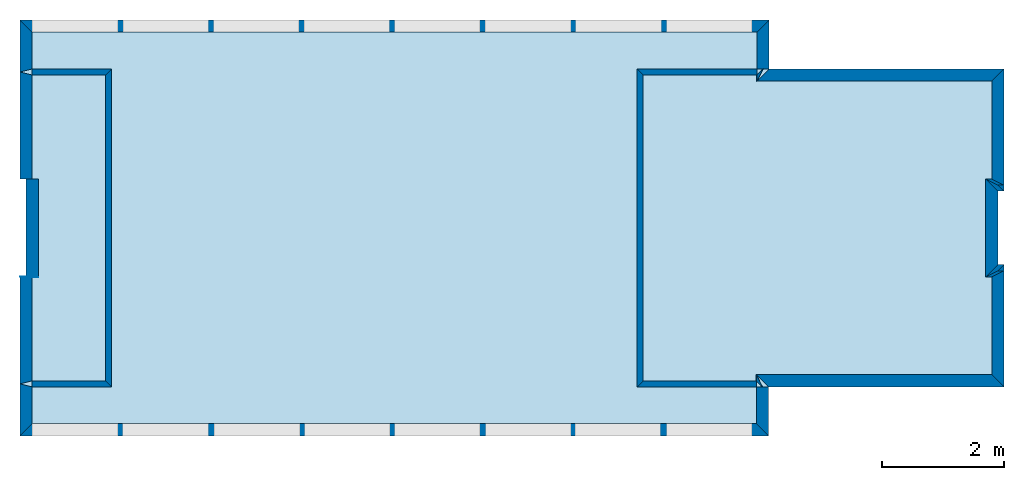
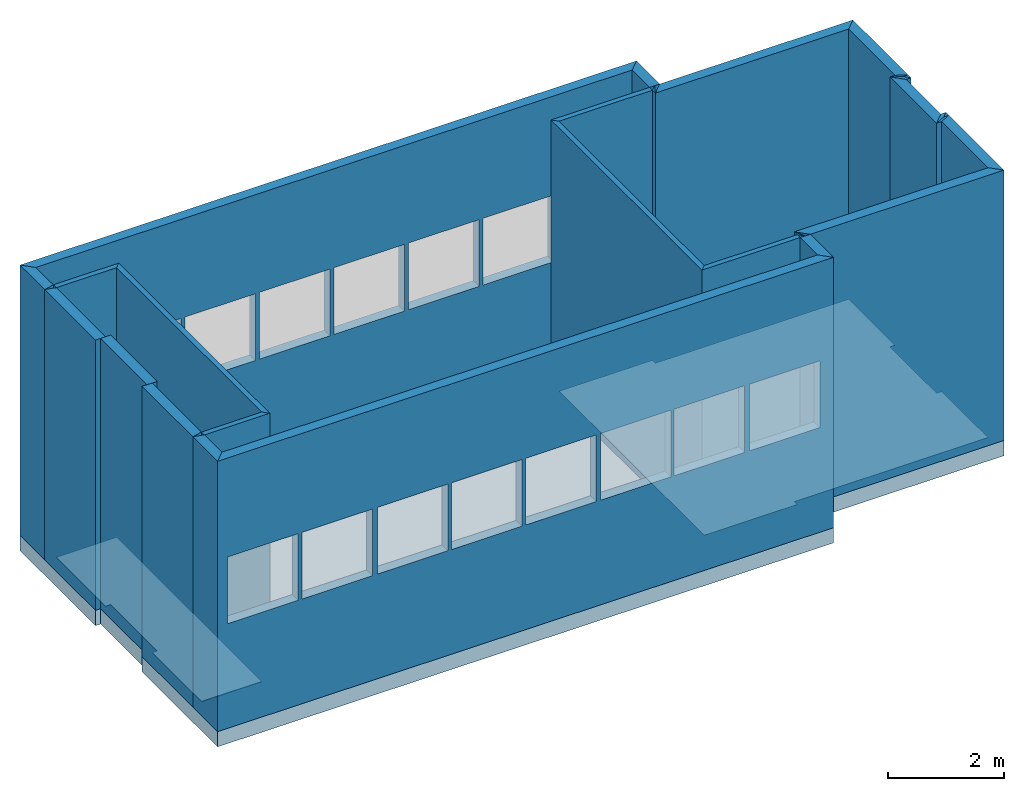
# One storey, part 1 of 17: 27 walls, 4 slabs, 16 openings.
"""IFC2X3 building model written with IfcOpenShell, lengths in metres."""

from ifc_helpers import new_model, entity, si_unit, converted_unit, derived_unit, frame, origin_with_axes, place, context, project, spatial, polyline, outline, extrude, material, layer, layer_set, layer_usage, element, save


model = new_model("IFC2X3")

# Units and contexts
context_of_model_1 = context(None, 3, world=origin_with_axes())
context_of_model_2 = context(None, 3, world=origin_with_axes())
context_of_model_3 = context(None, 2, world=origin_with_axes())
context_of_model_4 = context(None, 3, world=origin_with_axes())
ifc_project = project(units=[si_unit("LENGTHUNIT", "METRE"), si_unit("AREAUNIT", "SQUARE_METRE"), si_unit("ELECTRICCURRENTUNIT", "AMPERE"), si_unit("ELECTRICVOLTAGEUNIT", "VOLT"), si_unit("ELECTRICRESISTANCEUNIT", "OHM"), si_unit("POWERUNIT", "WATT"), si_unit("MASSUNIT", "GRAM"), si_unit("SOLIDANGLEUNIT", "STERADIAN"), si_unit("THERMODYNAMICTEMPERATUREUNIT", "KELVIN"), si_unit("PRESSUREUNIT", "PASCAL"), si_unit("LUMINOUSFLUXUNIT", "LUMEN"), si_unit("ILLUMINANCEUNIT", "LUX"), si_unit("FREQUENCYUNIT", "HERTZ"), si_unit("VOLUMEUNIT", "CUBIC_METRE"), si_unit("TIMEUNIT", "SECOND"), derived_unit("VOLUMETRICFLOWRATEUNIT", [(si_unit("TIMEUNIT", "SECOND"), -1), (si_unit("VOLUMEUNIT", "CUBIC_METRE"), 1)]), derived_unit("THERMALTRANSMITTANCEUNIT", [(si_unit("AREAUNIT", "SQUARE_METRE"), -1), (si_unit("THERMODYNAMICTEMPERATUREUNIT", "KELVIN"), -1), (si_unit("POWERUNIT", "WATT"), 1)]), converted_unit("PLANEANGLEUNIT", "DEGREE", entity("IfcPlaneAngleMeasure", 57.29577951308232), si_unit("PLANEANGLEUNIT", "RADIAN"), dimensions=[0, 0, 0, 0, 0, 0, 0])], contexts=[context_of_model_1, context_of_model_2, context_of_model_3, context_of_model_4])

# Site, building, storey
site = spatial("IfcSite", under=ifc_project, CompositionType="ELEMENT")
building_placement = place(None, origin_with_axes())
building = spatial("IfcBuilding", under=site, at=building_placement, Name="Tower", CompositionType="ELEMENT")
storey_placement = place(building_placement, frame((0.0, 0.0, 85.0), z_axis=(0.0, 0.0, 1.0), x_axis=(1.0, 0.0, 0.0)))
storey = spatial("IfcBuildingStorey", under=building, at=storey_placement, Name="Level 3", CompositionType="ELEMENT", Elevation=85.0)

# Slabs
ifc_material_1 = material()
ifc_layer_1 = layer(ifc_material_1, 0.3199999928474426, ventilated=False)
ifc_layer_set_1 = layer_set([ifc_layer_1])
ifc_layer_usage_1 = layer_usage(ifc_layer_set_1, "AXIS2", "POSITIVE", 0.0)
slab_1_placement = place(storey_placement, frame((0.1000000014901161, 1.399999976158142, 0.0), z_axis=(0.0, 0.0, 1.0), x_axis=(1.0, 0.0, 0.0)))
element("IfcSlab", 1, at=slab_1_placement, inside=storey, material=ifc_layer_usage_1, PredefinedType="FLOOR", context=context_of_model_1, shape_type="SweptSolid", body=[
    extrude(outline(polyline([(0.0, 0.0), (2.000000119209291, 0.0), (2.000000123679635, 0.0999999120831443), (3.199999932944773, 0.09999991089263416), (3.199999928474423, -1.430511357369829e-07), (5.200000405311582, -1.430511517241935e-07), (5.20000010013112, 3.839895351231112), (6.000000290865981, 3.839895315468318), (6.000001792110543, 16.088835068047), (3.400000456966503, 16.08883518427611), (3.399999975659022, 15.98883575648072), (1.800000786282108, 15.98883392065762), (1.800000790752515, 16.08883525580167), (-0.7999992926939846, 16.08883537203072), (-0.7999998398231419, 3.849762572348113), (1.720977860892539e-07, 3.849762536585327), (0.0, 0.0)])), frame((0.0, 0.0, 0.0), z_axis=(0.0, 0.0, 1.0), x_axis=(-4.470348091700783e-08, 0.9999999999999991, 0.0)), (0.0, 0.0, -1.0), 0.3199999928474426),
])
slab_2_placement = place(storey_placement, frame((-3.939895868301392, 6.600000381469727, 0.0), z_axis=(0.0, 0.0, 1.0), x_axis=(1.0, 0.0, 0.0)))
element("IfcSlab", 2, at=slab_2_placement, inside=storey, material=ifc_layer_usage_1, PredefinedType="FLOOR", context=context_of_model_1, shape_type="SweptSolid", body=[
    extrude(outline(polyline([(0.0, 0.0), (0.5999999046326159, 0.0), (0.5999961499604943, 11.84893989562933), (-4.708346343258583e-06, 11.84893965721037), (-4.191772597306827e-06, 10.54893946647561), (-5.200004597083773, 10.54893740018077), (-5.200005113657518, 11.84893759091553), (-5.800005137499329, 11.8489373524969), (-5.800000433073572, 0.009864171345491014), (-5.200000409231761, 0.009864409764117486), (-5.20000106497745, 1.960102160771091), (-7.788755649789618e-07, 1.960104227065886), (0.0, 0.0)])), frame((0.0, 0.0, 0.0), z_axis=(0.0, 0.0, 1.0), x_axis=(3.973643616619371e-07, 0.999999999999921, 0.0)), (0.0, 0.0, 1.0), 0.009999999776482582),
])
slab_3_placement = place(storey_placement, frame((-0.1000000089406967, 1.600000023841858, 0.0), z_axis=(0.0, 0.0, 1.0), x_axis=(1.0, 0.0, 0.0)))
element("IfcSlab", 3, at=slab_3_placement, inside=storey, material=ifc_layer_usage_1, PredefinedType="FLOOR", context=context_of_model_1, shape_type="SweptSolid", body=[
    extrude(outline(polyline([(0.0, 0.0), (1.60000002384186, -1.323488980084844e-23), (1.600000028498468, 0.09999990463256826), (3.19999969471246, 0.09999991953374611), (3.199999690055844, -1.490115952851313e-07), (4.80000054836273, -1.490116341429366e-07), (4.80000025033464, 3.839895397424694), (4.900000631804367, 3.839895392768063), (4.900000718422233, 5.699999953620113), (-0.09999963920562997, 5.70000018645077), (-0.09999984457333197, 3.849762340076265), (1.792685258227271e-07, 3.849762335419651), (0.0, 0.0)])), frame((0.0, 0.0, 0.0), z_axis=(0.0, 0.0, 1.0), x_axis=(-4.65661280368845e-08, 0.999999999999999, 0.0)), (0.0, 0.0, 1.0), 0.009999999776482582),
])
slab_4_placement = place(storey_placement, frame((-15.7888355255127, 6.500000476837158, 0.0), z_axis=(0.0, 0.0, 1.0), x_axis=(1.0, 0.0, 0.0)))
element("IfcSlab", 4, at=slab_4_placement, inside=storey, material=ifc_layer_usage_1, PredefinedType="FLOOR", context=context_of_model_1, shape_type="SweptSolid", body=[
    extrude(outline(polyline([(0.0, 0.0), (1.700000762939453, 0.0), (1.700001239776611, 0.1000003814697266), (3.305324554443359, 0.09904003143310547), (3.30534553527832, -0.001138687133789063), (5.000000357627869, 0.0), (5.000000476837158, 1.199999809265137), (0.0, 1.199999809265137), (0.0, 0.0)])), frame((0.0, 0.0, 0.0), z_axis=(0.0, 0.0, 1.0), x_axis=(0.0, -1.0, 0.0)), (0.0, 0.0, 1.0), 0.01999999955296516),
])

# Walls
ifc_material_2 = material(Name="Layer-Yttervegg 20.0cm")
ifc_layer_2 = layer(ifc_material_2, 0.2000000029802322, ventilated=False)
ifc_layer_set_2 = layer_set([ifc_layer_2], Name="ML-Yttervegg 20.0cm - 0.200")
ifc_layer_usage_2 = layer_usage(ifc_layer_set_2, "AXIS2", "POSITIVE", 0.0)
wall_1_placement = place(storey_placement, frame((0.09999991208314896, 3.400000095367432, 0.0), z_axis=(0.0, 0.0, 1.0), x_axis=(-1.0, -8.742277657347586e-08, 0.0)))
element("IfcWallStandardCase", 5, at=wall_1_placement, inside=storey, material=ifc_layer_usage_2, Name="Yttervegg 20.0cm", context=context_of_model_1, shape_type="SweptSolid", body=[
    extrude(outline(polyline([(0.0, 0.0), (0.0999999120831444, 0.0), (0.2999999299645421, 0.2000000476837162), (0.1999999880790708, 0.2000000476837158), (0.0, 0.0)])), frame((0.0, 0.0, 0.0), z_axis=(0.0, 0.0, 1.0), x_axis=(0.9999999999999961, -8.742278149038443e-08, 0.0)), (0.0, 0.0, 1.0), 5.68),
])
wall_2_placement = place(storey_placement, frame((-5.245365386485901e-08, 4.599999904632568, 0.0), z_axis=(0.0, 0.0, 1.0), x_axis=(1.0, 0.0, 0.0)))
element("IfcWallStandardCase", 6, at=wall_2_placement, inside=storey, material=ifc_layer_usage_2, Name="Yttervegg 20.0cm", context=context_of_model_1, shape_type="SweptSolid", body=[
    extrude(outline(polyline([(0.0, 0.0), (0.10000005394377, 0.0), (-0.09999995648704285, 0.1999998092651367), (-0.2000000250323843, 0.1999998092651367), (0.0, 0.0)])), origin_with_axes(), (0.0, 0.0, 1.0), 5.68),
])
wall_3_placement = place(storey_placement, frame((-3.739895582199097, 6.599999904632568, 0.0), z_axis=(0.0, 0.0, 1.0), x_axis=(-4.371138828673793e-08, 1.0, 0.0)))
element("IfcWallStandardCase", 7, at=wall_3_placement, inside=storey, material=ifc_layer_usage_2, Name="Yttervegg 20.0cm", context=context_of_model_1, shape_type="SweptSolid", body=[
    extrude(outline(polyline([(0.0, 0.0), (0.8000001907348633, 0.0), (0.600000381469726, 0.2000000476837155), (4.768371582176146e-07, 0.2000002861022946), (0.0, 0.0)])), frame((0.0, 0.0, 0.0), z_axis=(0.0, 0.0, 1.0), x_axis=(0.999999999999999, -4.371138963349459e-08, 0.0)), (0.0, 0.0, 1.0), 5.68),
])

# Wall, openings
ifc_material_3 = material()
ifc_layer_3 = layer(ifc_material_3, 0.2, ventilated=False)
ifc_layer_set_3 = layer_set([ifc_layer_3])
ifc_layer_usage_3 = layer_usage(ifc_layer_set_3, "AXIS2", "POSITIVE", 0.0)
wall_4_placement = place(storey_placement, frame((-3.739895582199097, 7.400000095367432, 0.0), z_axis=(0.0, 0.0, 1.0), x_axis=(-1.0, 1.509958025280866e-07, 0.0)))
wall_4 = element("IfcWallStandardCase", 8, at=wall_4_placement, inside=storey, material=ifc_layer_usage_3, context=context_of_model_1, shape_type="SweptSolid", body=[
    extrude(outline(polyline([(0.0, 0.0), (12.24893975257877, -1.058791184067875e-22), (12.04893992774211, 0.1999997936936115), (0.2000000321121897, 0.1999998248366815), (0.0, 0.0)])), frame((0.0, 0.0, 0.0), z_axis=(0.0, 0.0, 1.0), x_axis=(0.9999999999999973, 7.313809583869059e-08, 0.0)), (0.0, 0.0, 1.0), 5.68),
])
opening_1_placement = place(wall_4_placement, frame((10.64894029458421, 0.2000004635360728, 2.2), z_axis=(0.0, 0.0, 1.0), x_axis=(1.0, 0.0, 0.0)))
element("IfcOpeningElement", 9, at=opening_1_placement, cuts=wall_4, context=context_of_model_1, shape_type="SweptSolid", body=[
    extrude(outline(polyline([(0.0, 0.0), (1.399999976158142, 0.0), (1.399999976158142, 1.39999961853027), (0.0, 1.39999961853027), (0.0, 0.0)])), frame((0.0, 0.0, 0.0), z_axis=(1.153203098282065e-07, 0.9999999999999933, 0.0), x_axis=(0.0, 0.0, 1.0)), (0.0, 1.153203098282065e-07, -0.9999999999999933), 0.2),
])
opening_2_placement = place(wall_4_placement, frame((9.167823046049076, 0.2000002398935905, 2.2), z_axis=(0.0, 0.0, 1.0), x_axis=(1.0, 0.0, 0.0)))
element("IfcOpeningElement", 10, at=opening_2_placement, cuts=wall_4, context=context_of_model_1, shape_type="SweptSolid", body=[
    extrude(outline(polyline([(0.0, 0.0), (1.399999976158142, 0.0), (1.399999976158142, 1.399999618530248), (0.0, 1.399999618530248), (0.0, 0.0)])), frame((0.0, 0.0, 0.0), z_axis=(1.153203104626217e-07, 0.9999999999999934, 0.0), x_axis=(0.0, 0.0, 1.0)), (0.0, 1.153203104626217e-07, -0.9999999999999933), 0.2),
])
opening_3_placement = place(wall_4_placement, frame((7.686705797513865, 0.2000004930882655, 2.2), z_axis=(0.0, 0.0, 1.0), x_axis=(1.0, 0.0, 0.0)))
element("IfcOpeningElement", 11, at=opening_3_placement, cuts=wall_4, context=context_of_model_1, shape_type="SweptSolid", body=[
    extrude(outline(polyline([(0.0, 0.0), (1.399999976158142, 0.0), (1.399999976158142, 1.399999618530224), (0.0, 1.399999618530224), (0.0, 0.0)])), frame((0.0, 0.0, 0.0), z_axis=(1.153203098282103e-07, 0.9999999999999933, 0.0), x_axis=(0.0, 0.0, 1.0)), (0.0, 1.153203098282103e-07, -0.9999999999999933), 0.2),
])
opening_4_placement = place(wall_4_placement, frame((6.20558759530441, 0.2000002694456393, 2.2), z_axis=(0.0, 0.0, 1.0), x_axis=(1.0, 0.0, 0.0)))
element("IfcOpeningElement", 12, at=opening_4_placement, cuts=wall_4, context=context_of_model_1, shape_type="SweptSolid", body=[
    extrude(outline(polyline([(0.0, 0.0), (1.399999976158142, 0.0), (1.399999976158142, 1.3999996185302), (0.0, 1.3999996185302), (0.0, 0.0)])), frame((0.0, 0.0, 0.0), z_axis=(1.153203098282124e-07, 0.9999999999999934, 0.0), x_axis=(0.0, 0.0, 1.0)), (0.0, 1.153203098282124e-07, -0.9999999999999933), 0.2),
])
opening_5_placement = place(wall_4_placement, frame((4.724470346769271, 0.200000045803157, 2.2), z_axis=(0.0, 0.0, 1.0), x_axis=(1.0, 0.0, 0.0)))
element("IfcOpeningElement", 13, at=opening_5_placement, cuts=wall_4, context=context_of_model_1, shape_type="SweptSolid", body=[
    extrude(outline(polyline([(0.0, 0.0), (1.399999976158142, 0.0), (1.399999976158142, 1.399999618530173), (0.0, 1.399999618530173), (0.0, 0.0)])), frame((0.0, 0.0, 0.0), z_axis=(1.153203098282146e-07, 0.9999999999999933, 0.0), x_axis=(0.0, 0.0, 1.0)), (0.0, 1.153203098282146e-07, -0.9999999999999933), 0.2),
])
opening_6_placement = place(wall_4_placement, frame((3.243353098234131, 0.1999998221606747, 2.2), z_axis=(0.0, 0.0, 1.0), x_axis=(1.0, 0.0, 0.0)))
element("IfcOpeningElement", 14, at=opening_6_placement, cuts=wall_4, context=context_of_model_1, shape_type="SweptSolid", body=[
    extrude(outline(polyline([(0.0, 0.0), (1.399999976158142, 0.0), (1.399999976158142, 1.399999618530151), (0.0, 1.399999618530151), (0.0, 0.0)])), frame((0.0, 0.0, 0.0), z_axis=(1.153203104626297e-07, 0.9999999999999933, 0.0), x_axis=(0.0, 0.0, 1.0)), (0.0, 1.153203104626297e-07, -0.9999999999999933), 0.2),
])
opening_7_placement = place(wall_4_placement, frame((1.762234896024604, 0.2000000753552058, 2.2), z_axis=(0.0, 0.0, 1.0), x_axis=(1.0, 0.0, 0.0)))
element("IfcOpeningElement", 15, at=opening_7_placement, cuts=wall_4, context=context_of_model_1, shape_type="SweptSolid", body=[
    extrude(outline(polyline([(0.0, 0.0), (1.399999976158142, 0.0), (1.399999976158142, 1.399999618530126), (0.0, 1.399999618530126), (0.0, 0.0)])), frame((0.0, 0.0, 0.0), z_axis=(1.153203098282184e-07, 0.9999999999999933, 0.0), x_axis=(0.0, 0.0, 1.0)), (0.0, 1.153203098282184e-07, -0.9999999999999933), 0.2),
])
opening_8_placement = place(wall_4_placement, frame((0.2783190902079702, 0.1999998512901531, 2.2), z_axis=(0.0, 0.0, 1.0), x_axis=(1.0, 0.0, 0.0)))
element("IfcOpeningElement", 16, at=opening_8_placement, cuts=wall_4, context=context_of_model_1, shape_type="SweptSolid", body=[
    extrude(outline(polyline([(0.0, 0.0), (1.399999976158142, 0.0), (1.399999976158142, 1.399999618530102), (0.0, 1.399999618530102), (0.0, 0.0)])), frame((0.0, 0.0, 0.0), z_axis=(1.153203098282204e-07, 0.9999999999999933, 0.0), x_axis=(0.0, 0.0, 1.0)), (0.0, 1.153203098282204e-07, -0.9999999999999933), 0.2),
])

# Walls
ifc_material_4 = material()
ifc_layer_4 = layer(ifc_material_4, 0.2, ventilated=False)
ifc_layer_set_4 = layer_set([ifc_layer_4])
ifc_layer_usage_4 = layer_usage(ifc_layer_set_4, "AXIS2", "POSITIVE", 0.0)
wall_5_placement = place(storey_placement, frame((-15.98883533477783, 7.400001049041748, 0.0), z_axis=(0.0, 0.0, 1.0), x_axis=(-4.371138828673793e-08, -1.0, 0.0)))
element("IfcWallStandardCase", 17, at=wall_5_placement, inside=storey, material=ifc_layer_usage_4, context=context_of_model_1, shape_type="SweptSolid", body=[
    extrude(outline(polyline([(0.0, 0.0), (0.8500008583068847, 0.0), (0.8000006675720213, 0.1999998092651369), (0.1999998092651368, 0.1999998092651379), (0.0, 0.0)])), frame((0.0, 0.0, 0.0), z_axis=(0.0, 0.0, 1.0), x_axis=(0.9999999999999991, 4.371139137835724e-08, 0.0)), (0.0, 0.0, 1.0), 5.68),
])
ifc_material_5 = material()
ifc_layer_5 = layer(ifc_material_5, 0.1, ventilated=False)
ifc_layer_set_5 = layer_set([ifc_layer_5])
ifc_layer_usage_5 = layer_usage(ifc_layer_set_5, "AXIS2", "POSITIVE", 0.0)
wall_6_placement = place(storey_placement, frame((-15.7888355255127, 6.500000476837158, 0.0), z_axis=(0.0, 0.0, 1.0), x_axis=(1.0, 0.0, 0.0)))
element("IfcWallStandardCase", 18, at=wall_6_placement, inside=storey, material=ifc_layer_usage_5, context=context_of_model_1, shape_type="SweptSolid", body=[
    extrude(outline(polyline([(0.0, 0.0), (1.199999809265137, 0.0), (1.300000190734863, 0.09999990463256836), (0.0, 0.09999990463256836), (0.0, 0.0)])), origin_with_axes(), (0.0, 0.0, 1.0), 5.68),
])
wall_7_placement = place(storey_placement, frame((-14.58883571624756, 6.500000476837158, 0.0), z_axis=(0.0, 0.0, 1.0), x_axis=(-4.371138828673793e-08, -1.0, 0.0)))
element("IfcWallStandardCase", 19, at=wall_7_placement, inside=storey, material=ifc_layer_usage_5, context=context_of_model_1, shape_type="SweptSolid", body=[
    extrude(outline(polyline([(0.0, 0.0), (5.000000476837157, 0.0), (5.100000500679015, 0.1000003814697265), (-0.09999990463256864, 0.1000003814697269), (0.0, 0.0)])), frame((0.0, 0.0, 0.0), z_axis=(0.0, 0.0, 1.0), x_axis=(0.9999999999999991, 4.371139015770818e-08, 0.0)), (0.0, 0.0, 1.0), 5.68),
])
wall_8_placement = place(storey_placement, frame((-14.58883571624756, 1.5, 0.0), z_axis=(0.0, 0.0, 1.0), x_axis=(-1.0, 1.509958025280866e-07, 0.0)))
element("IfcWallStandardCase", 20, at=wall_8_placement, inside=storey, material=ifc_layer_usage_5, context=context_of_model_1, shape_type="SweptSolid", body=[
    extrude(outline(polyline([(0.0, 0.0), (1.199999809265142, 0.0), (1.199999799331019, 0.100000143051147), (-0.1000003914038372, 0.1000000139077105), (0.0, 0.0)])), frame((0.0, 0.0, 0.0), z_axis=(0.0, 0.0, 1.0), x_axis=(0.9999999999999987, 5.165470854219175e-08, 0.0)), (0.0, 0.0, 1.0), 5.68),
])
ifc_material_6 = material()
ifc_layer_6 = layer(ifc_material_6, 0.2, ventilated=False)
ifc_layer_set_6 = layer_set([ifc_layer_6])
ifc_layer_usage_6 = layer_usage(ifc_layer_set_6, "AXIS2", "POSITIVE", 0.0)
wall_9_placement = place(storey_placement, frame((-15.98883533477783, 1.450000047683716, 0.0), z_axis=(0.0, 0.0, 1.0), x_axis=(-4.371138828673793e-08, -1.0, 0.0)))
element("IfcWallStandardCase", 21, at=wall_9_placement, inside=storey, material=ifc_layer_usage_6, context=context_of_model_1, shape_type="SweptSolid", body=[
    extrude(outline(polyline([(0.0, 0.0), (0.8500000834465025, 0.0), (0.6500000953674314, 0.1999998092651363), (0.05000007152557353, 0.1999998092651369), (0.0, 0.0)])), frame((0.0, 0.0, 0.0), z_axis=(0.0, 0.0, 1.0), x_axis=(0.9999999999999991, 4.371138942904995e-08, 0.0)), (0.0, 0.0, 1.0), 5.68),
])

# Wall, openings
ifc_material_7 = material()
ifc_layer_7 = layer(ifc_material_7, 0.2, ventilated=False)
ifc_layer_set_7 = layer_set([ifc_layer_7])
ifc_layer_usage_7 = layer_usage(ifc_layer_set_7, "AXIS2", "POSITIVE", 0.0)
wall_10_placement = place(storey_placement, frame((-15.98883533477783, 0.5999999642372131, 0.0), z_axis=(0.0, 0.0, 1.0), x_axis=(1.0, 0.0, 0.0)))
wall_10 = element("IfcWallStandardCase", 22, at=wall_10_placement, inside=storey, material=ifc_layer_usage_7, context=context_of_model_1, shape_type="SweptSolid", body=[
    extrude(outline(polyline([(0.0, 0.0), (12.23907279968262, 0.0), (12.03907299041748, 0.199999988079071), (0.1999998092651367, 0.199999988079071), (0.0, 0.0)])), origin_with_axes(), (0.0, 0.0, 1.0), 5.68),
])
opening_9_placement = place(wall_10_placement, frame((0.1999998092651367, 0.199999988079071, 2.2), z_axis=(0.0, 0.0, 1.0), x_axis=(1.0, 0.0, 0.0)))
element("IfcOpeningElement", 23, at=opening_9_placement, cuts=wall_10, context=context_of_model_1, shape_type="SweptSolid", body=[
    extrude(outline(polyline([(0.0, 0.0), (1.399999976158142, 0.0), (1.399999976158142, 1.399999618530103), (0.0, 1.399999618530103), (0.0, 0.0)])), frame((0.0, 0.0, 0.0), z_axis=(0.0, 1.0, 0.0), x_axis=(0.0, 0.0, 1.0)), (0.0, 0.0, -1.0), 0.2),
])
opening_10_placement = place(wall_10_placement, frame((1.679572105407715, 0.199999988079071, 2.2), z_axis=(0.0, 0.0, 1.0), x_axis=(1.0, 0.0, 0.0)))
element("IfcOpeningElement", 24, at=opening_10_placement, cuts=wall_10, context=context_of_model_1, shape_type="SweptSolid", body=[
    extrude(outline(polyline([(0.0, 0.0), (1.399999976158142, 0.0), (1.399999976158142, 1.399999618530103), (0.0, 1.399999618530103), (0.0, 0.0)])), frame((0.0, 0.0, 0.0), z_axis=(0.0, 1.0, 0.0), x_axis=(0.0, 0.0, 1.0)), (0.0, 0.0, -1.0), 0.2),
])
opening_11_placement = place(wall_10_placement, frame((3.175571441650391, 0.199999988079071, 2.2), z_axis=(0.0, 0.0, 1.0), x_axis=(1.0, 0.0, 0.0)))
element("IfcOpeningElement", 25, at=opening_11_placement, cuts=wall_10, context=context_of_model_1, shape_type="SweptSolid", body=[
    extrude(outline(polyline([(0.0, 0.0), (1.399999976158142, 0.0), (1.399999976158142, 1.399999618530103), (0.0, 1.399999618530103), (0.0, 0.0)])), frame((0.0, 0.0, 0.0), z_axis=(0.0, 1.0, 0.0), x_axis=(0.0, 0.0, 1.0)), (0.0, 0.0, -1.0), 0.2),
])
opening_12_placement = place(wall_10_placement, frame((4.649572372436523, 0.199999988079071, 2.2), z_axis=(0.0, 0.0, 1.0), x_axis=(1.0, 0.0, 0.0)))
element("IfcOpeningElement", 26, at=opening_12_placement, cuts=wall_10, context=context_of_model_1, shape_type="SweptSolid", body=[
    extrude(outline(polyline([(0.0, 0.0), (1.399999976158142, 0.0), (1.399999976158142, 1.399999618530103), (0.0, 1.399999618530103), (0.0, 0.0)])), frame((0.0, 0.0, 0.0), z_axis=(0.0, 1.0, 0.0), x_axis=(0.0, 0.0, 1.0)), (0.0, 0.0, -1.0), 0.2),
])
opening_13_placement = place(wall_10_placement, frame((6.123573303222656, 0.199999988079071, 2.2), z_axis=(0.0, 0.0, 1.0), x_axis=(1.0, 0.0, 0.0)))
element("IfcOpeningElement", 27, at=opening_13_placement, cuts=wall_10, context=context_of_model_1, shape_type="SweptSolid", body=[
    extrude(outline(polyline([(0.0, 0.0), (1.399999976158142, 0.0), (1.399999976158142, 1.399999618530103), (0.0, 1.399999618530103), (0.0, 0.0)])), frame((0.0, 0.0, 0.0), z_axis=(0.0, 1.0, 0.0), x_axis=(0.0, 0.0, 1.0)), (0.0, 0.0, -1.0), 0.2),
])
opening_14_placement = place(wall_10_placement, frame((7.608574867248535, 0.199999988079071, 2.2), z_axis=(0.0, 0.0, 1.0), x_axis=(1.0, 0.0, 0.0)))
element("IfcOpeningElement", 28, at=opening_14_placement, cuts=wall_10, context=context_of_model_1, shape_type="SweptSolid", body=[
    extrude(outline(polyline([(0.0, 0.0), (1.399999976158142, 0.0), (1.399999976158142, 1.399999618530103), (0.0, 1.399999618530103), (0.0, 0.0)])), frame((0.0, 0.0, 0.0), z_axis=(0.0, 1.0, 0.0), x_axis=(0.0, 0.0, 1.0)), (0.0, 0.0, -1.0), 0.2),
])
opening_15_placement = place(wall_10_placement, frame((9.071574211120605, 0.199999988079071, 2.2), z_axis=(0.0, 0.0, 1.0), x_axis=(1.0, 0.0, 0.0)))
element("IfcOpeningElement", 29, at=opening_15_placement, cuts=wall_10, context=context_of_model_1, shape_type="SweptSolid", body=[
    extrude(outline(polyline([(0.0, 0.0), (1.399999976158142, 0.0), (1.399999976158142, 1.399999618530103), (0.0, 1.399999618530103), (0.0, 0.0)])), frame((0.0, 0.0, 0.0), z_axis=(0.0, 1.0, 0.0), x_axis=(0.0, 0.0, 1.0)), (0.0, 0.0, -1.0), 0.2),
])
opening_16_placement = place(wall_10_placement, frame((10.56757545471191, 0.199999988079071, 2.2), z_axis=(0.0, 0.0, 1.0), x_axis=(1.0, 0.0, 0.0)))
element("IfcOpeningElement", 30, at=opening_16_placement, cuts=wall_10, context=context_of_model_1, shape_type="SweptSolid", body=[
    extrude(outline(polyline([(0.0, 0.0), (1.399999976158142, 0.0), (1.399999976158142, 1.399999618530103), (0.0, 1.399999618530103), (0.0, 0.0)])), frame((0.0, 0.0, 0.0), z_axis=(0.0, 1.0, 0.0), x_axis=(0.0, 0.0, 1.0)), (0.0, 0.0, -1.0), 0.2),
])

# Walls
wall_11_placement = place(storey_placement, frame((-3.749762535095215, 0.5999999642372131, 0.0), z_axis=(0.0, 0.0, 1.0), x_axis=(-4.371138828673793e-08, 1.0, 0.0)))
element("IfcWallStandardCase", 31, at=wall_11_placement, inside=storey, material=ifc_layer_usage_2, Name="Yttervegg 20.0cm", context=context_of_model_1, shape_type="SweptSolid", body=[
    extrude(outline(polyline([(0.0, 0.0), (0.8000000119209291, -6.617444900424221e-24), (0.800000011920929, 0.1999998092651365), (0.1999999880790711, 0.1999998092651364), (0.0, 0.0)])), frame((0.0, 0.0, 0.0), z_axis=(0.0, 0.0, 1.0), x_axis=(0.999999999999999, -4.371138996685581e-08, 0.0)), (0.0, 0.0, 1.0), 5.68),
])
wall_12_placement = place(storey_placement, frame((-3.949762344360352, 1.5, 0.0), z_axis=(0.0, 0.0, 1.0), x_axis=(-1.0, 1.509958025280866e-07, 0.0)))
element("IfcWallStandardCase", 32, at=wall_12_placement, inside=storey, material=ifc_layer_usage_5, context=context_of_model_1, shape_type="SweptSolid", body=[
    extrude(outline(polyline([(0.0, 0.0), (1.850237846374515, 0.0), (1.950237744564166, 0.1000000302847687), (-6.442918429059665e-09, 0.1000000238418577), (0.0, 0.0)])), frame((0.0, 0.0, 0.0), z_axis=(0.0, 0.0, 1.0), x_axis=(0.9999999999999962, 8.656662868464251e-08, 0.0)), (0.0, 0.0, 1.0), 5.68),
])
wall_13_placement = place(storey_placement, frame((-5.800000190734863, 1.50000011920929, 0.0), z_axis=(0.0, 0.0, 1.0), x_axis=(-4.371138828673793e-08, 1.0, 0.0)))
element("IfcWallStandardCase", 33, at=wall_13_placement, inside=storey, material=ifc_layer_usage_5, context=context_of_model_1, shape_type="SweptSolid", body=[
    extrude(outline(polyline([(0.0, 0.0), (5.000000357627869, 0.0), (5.100000262260437, 0.0999999046325687), (-0.1000000238418578, 0.09999990463256829), (0.0, 0.0)])), frame((0.0, 0.0, 0.0), z_axis=(0.0, 0.0, 1.0), x_axis=(0.9999999999999991, -4.371138995641915e-08, 0.0)), (0.0, 0.0, 1.0), 5.68),
])
wall_14_placement = place(storey_placement, frame((-5.800000190734863, 6.500000476837158, 0.0), z_axis=(0.0, 0.0, 1.0), x_axis=(1.0, 0.0, 0.0)))
element("IfcWallStandardCase", 34, at=wall_14_placement, inside=storey, material=ifc_layer_usage_5, context=context_of_model_1, shape_type="SweptSolid", body=[
    extrude(outline(polyline([(0.0, 0.0), (1.860104560852051, 0.0), (1.860104322433472, 0.09999990463256836), (-0.09999990463256836, 0.09999990463256836), (0.0, 0.0)])), origin_with_axes(), (0.0, 0.0, 1.0), 5.68),
])
wall_15_placement = place(storey_placement, frame((0.1000000014901161, 1.399999976158142, 0.0), z_axis=(0.0, 0.0, 1.0), x_axis=(-4.371138828673793e-08, 1.0, 0.0)))
element("IfcWallStandardCase", 35, at=wall_15_placement, inside=storey, material=ifc_layer_usage_2, Name="Yttervegg 20.0cm", context=context_of_model_1, shape_type="SweptSolid", body=[
    extrude(outline(polyline([(0.0, 0.0), (2.000000119209291, 0.0), (1.800000080466272, 0.2000000044703497), (0.2000000566244123, 0.2000000014901143), (0.0, 0.0)])), frame((0.0, 0.0, 0.0), z_axis=(0.0, 0.0, 1.0), x_axis=(1.0, 9.92090919679804e-10, 0.0)), (0.0, 0.0, 1.0), 5.68),
])
wall_16_placement = place(storey_placement, frame((0.09999991953372955, 3.299999952316284, 0.0), z_axis=(0.0, 0.0, 1.0), x_axis=(-1.0, -8.742277657347586e-08, 0.0)))
element("IfcWallStandardCase", 36, at=wall_16_placement, inside=storey, material=ifc_layer_usage_5, context=context_of_model_1, shape_type="SweptSolid", body=[
    extrude(outline(polyline([(0.0, 0.0), (0.09999991208314898, 0.0), (0.2999999076128005, 0.09999990463256865), (0.2000000029802322, 0.09999990463256886), (0.0, 0.0)])), frame((0.0, 0.0, 0.0), z_axis=(0.0, 0.0, 1.0), x_axis=(0.9999999999999961, -8.742278149038043e-08, 0.0)), (0.0, 0.0, 1.0), 5.68),
])
wall_17_placement = place(storey_placement, frame((4.579669976578771e-15, 3.400000095367432, 0.0), z_axis=(0.0, 0.0, 1.0), x_axis=(-4.371138828673793e-08, 1.0, 0.0)))
element("IfcWallStandardCase", 37, at=wall_17_placement, inside=storey, material=ifc_layer_usage_2, Name="Yttervegg 20.0cm", context=context_of_model_1, shape_type="SweptSolid", body=[
    extrude(outline(polyline([(0.0, 0.0), (1.199999809265139, 0.0), (1.399999627272554, 0.2000000162901147), (-0.200000038941438, 0.1999999968213553), (0.0, 0.0)])), frame((0.0, 0.0, 0.0), z_axis=(0.0, 0.0, 1.0), x_axis=(1.0, -1.01701678366724e-15, 0.0)), (0.0, 0.0, 1.0), 5.68),
])
wall_18_placement = place(storey_placement, frame((-7.450580596923828e-08, 4.699999809265137, 0.0), z_axis=(0.0, 0.0, 1.0), x_axis=(1.0, 0.0, 0.0)))
element("IfcWallStandardCase", 38, at=wall_18_placement, inside=storey, material=ifc_layer_usage_5, context=context_of_model_1, shape_type="SweptSolid", body=[
    extrude(outline(polyline([(0.0, 0.0), (0.1000000685453415, 0.0), (-0.09999993443489075, 0.09999990463256836), (-0.2000000029802322, 0.09999990463256836), (0.0, 0.0)])), origin_with_axes(), (0.0, 0.0, 1.0), 5.68),
])
wall_19_placement = place(storey_placement, frame((0.1000000014901161, 4.599999904632568, 0.0), z_axis=(0.0, 0.0, 1.0), x_axis=(-4.371138828673793e-08, 1.0, 0.0)))
element("IfcWallStandardCase", 39, at=wall_19_placement, inside=storey, material=ifc_layer_usage_2, Name="Yttervegg 20.0cm", context=context_of_model_1, shape_type="SweptSolid", body=[
    extrude(outline(polyline([(0.0, 0.0), (2.00000047683716, 0.0), (1.800000676512718, 0.2000000044703375), (0.1999998182058313, 0.2000000014901266), (0.0, 0.0)])), frame((0.0, 0.0, 0.0), z_axis=(0.0, 0.0, 1.0), x_axis=(1.0, 9.920829221486003e-10, 0.0)), (0.0, 0.0, 1.0), 5.68),
])
wall_20_placement = place(storey_placement, frame((0.09999991208314896, 6.600000381469727, 0.0), z_axis=(0.0, 0.0, 1.0), x_axis=(-1.0, -1.509958025280866e-07, 0.0)))
element("IfcWallStandardCase", 40, at=wall_20_placement, inside=storey, material=ifc_layer_usage_2, Name="Yttervegg 20.0cm", context=context_of_model_1, shape_type="SweptSolid", body=[
    extrude(outline(polyline([(0.0, 0.0), (3.839895494282275, 0.0), (4.039895566801911, 0.1999997844291838), (0.200000020365571, 0.1999997844291904), (0.0, 0.0)])), frame((0.0, 0.0, 0.0), z_axis=(0.0, 0.0, 1.0), x_axis=(0.9999999999999997, -2.681607627142525e-08, 0.0)), (0.0, 0.0, 1.0), 5.68),
])
wall_21_placement = place(storey_placement, frame((-3.839895725250244, 6.599999904632568, 0.0), z_axis=(0.0, 0.0, 1.0), x_axis=(-4.371138828673793e-08, 1.0, 0.0)))
element("IfcWallStandardCase", 41, at=wall_21_placement, inside=storey, material=ifc_layer_usage_5, context=context_of_model_1, shape_type="SweptSolid", body=[
    extrude(outline(polyline([(0.0, 0.0), (-3.371739842166629e-07, -3.371755919557258e-07), (0.1414208841930086, -1.387778780781446e-17), (0.2121316634626929, 0.07071111644688433), (0.0, 0.0)])), frame((0.0, 0.0, 0.0), z_axis=(0.0, 0.0, 1.0), x_axis=(-0.707105064396276, 0.707108497972651, 0.0)), (0.0, 0.0, 1.0), 5.68),
])
wall_22_placement = place(storey_placement, frame((-3.849762439727783, 1.399999976158142, 0.0), z_axis=(0.0, 0.0, 1.0), x_axis=(1.0, 0.0, 0.0)))
element("IfcWallStandardCase", 42, at=wall_22_placement, inside=storey, material=ifc_layer_usage_5, context=context_of_model_1, shape_type="SweptSolid", body=[
    extrude(outline(polyline([(0.0, 0.0), (0.0, 0.0), (0.2236067977500044, 0.0), (0.1341640360004059, 0.04472132756277154), (0.0, 0.0)])), frame((0.0, 0.0, 0.0), z_axis=(0.0, 0.0, 1.0), x_axis=(-0.4472131690037871, 0.8944274042478741, 0.0)), (0.0, 0.0, 1.0), 5.68),
])
wall_23_placement = place(storey_placement, frame((-3.749762535095215, 1.399999976158142, 0.0), z_axis=(0.0, 0.0, 1.0), x_axis=(1.0, 0.0, 0.0)))
element("IfcWallStandardCase", 43, at=wall_23_placement, inside=storey, material=ifc_layer_usage_2, Name="Yttervegg 20.0cm", context=context_of_model_1, shape_type="SweptSolid", body=[
    extrude(outline(polyline([(0.0, 0.0), (3.849762536585331, 0.0), (3.649762526154518, 0.2000000476837158), (-0.1999998092651367, 0.2000000476837158), (0.0, 0.0)])), origin_with_axes(), (0.0, 0.0, 1.0), 5.68),
])
wall_24_placement = place(storey_placement, frame((-15.98883533477783, 6.550000190734863, 0.0), z_axis=(0.0, 0.0, 1.0), x_axis=(-4.371138828673793e-08, -1.0, 0.0)))
element("IfcWallStandardCase", 44, at=wall_24_placement, inside=storey, material=ifc_layer_usage_2, Name="Yttervegg 20.0cm", context=context_of_model_1, shape_type="SweptSolid", body=[
    extrude(outline(polyline([(0.0, 0.0), (1.750000476837158, 0.0), (1.750000476837157, 0.1999998092651369), (0.04999971389770468, 0.1999998092651365), (0.0, 0.0)])), frame((0.0, 0.0, 0.0), z_axis=(0.0, 0.0, 1.0), x_axis=(0.9999999999999991, 4.371138957212315e-08, 0.0)), (0.0, 0.0, 1.0), 5.68),
])
wall_25_placement = place(storey_placement, frame((-15.88883590698242, 4.799999237060547, 0.0), z_axis=(0.0, 0.0, 1.0), x_axis=(1.148381556959066e-06, -1.0, 0.0)))
element("IfcWallStandardCase", 45, at=wall_25_placement, inside=storey, material=ifc_layer_usage_2, Name="Yttervegg 20.0cm", context=context_of_model_1, shape_type="SweptSolid", body=[
    extrude(outline(polyline([(0.0, 0.0), (1.599999189377968, 0.0), (1.60532355194039, 0.1990384992072016), (2.384196089756942e-07, 0.2000007629393097), (0.0, 0.0)])), frame((0.0, 0.0, 0.0), z_axis=(0.0, 0.0, 1.0), x_axis=(0.999999999999999, 4.371199396615053e-08, 0.0)), (0.0, 0.0, 1.0), 5.68),
])
ifc_material_8 = material(Name="Layer-Yttervegg 15.0cm")
ifc_layer_8 = layer(ifc_material_8, 0.1490441709756851, ventilated=False)
ifc_layer_set_8 = layer_set([ifc_layer_8], Name="ML-Yttervegg 15.0cm - 0.149")
ifc_layer_usage_8 = layer_usage(ifc_layer_set_8, "AXIS2", "POSITIVE", 0.0)
wall_26_placement = place(storey_placement, frame((-15.88883399963379, 3.200000047683716, 0.0), z_axis=(0.0, 0.0, 1.0), x_axis=(-1.0, -8.742277657347586e-08, 0.0)))
element("IfcWallStandardCase", 46, at=wall_26_placement, inside=storey, material=ifc_layer_usage_8, Name="Yttervegg 15.0cm", context=context_of_model_1, shape_type="SweptSolid", body=[
    extrude(outline(polyline([(0.0, 0.0), (0.1000013351440434, 0.0), (-0.098859786987306, 0.005345106124877761), (-0.1990385055541982, 0.005324125289916623), (0.0, 0.0)])), frame((0.0, 0.0, 0.0), z_axis=(0.0, 0.0, 1.0), x_axis=(0.9999999999999962, -8.742278086076025e-08, 0.0)), (0.0, 0.0, 1.0), 5.68),
])
ifc_material_9 = material(Name="Layer-Yttervegg 20.0cm")
ifc_layer_9 = layer(ifc_material_9, 0.1992644965648651, ventilated=False)
ifc_layer_set_9 = layer_set([ifc_layer_9], Name="ML-Yttervegg 20.0cm - 0.199")
ifc_layer_usage_9 = layer_usage(ifc_layer_set_9, "AXIS2", "POSITIVE", 0.0)
wall_27_placement = place(storey_placement, frame((-15.98883533477783, 3.200000047683716, 0.0), z_axis=(0.0, 0.0, 1.0), x_axis=(-4.371138828673793e-08, -1.0, 0.0)))
element("IfcWallStandardCase", 47, at=wall_27_placement, inside=storey, material=ifc_layer_usage_9, Name="Yttervegg 20.0cm", context=context_of_model_1, shape_type="SweptSolid", body=[
    extrude(outline(polyline([(0.0, 0.0), (1.75, 0.0), (1.699999928474426, 0.1999998092651369), (0.005345106124878006, 0.1988611221313482), (0.0, 0.0)])), frame((0.0, 0.0, 0.0), z_axis=(0.0, 0.0, 1.0), x_axis=(0.9999999999999991, 4.371139031686004e-08, 0.0)), (0.0, 0.0, 1.0), 5.68),
])

save(model, "model.ifc")
